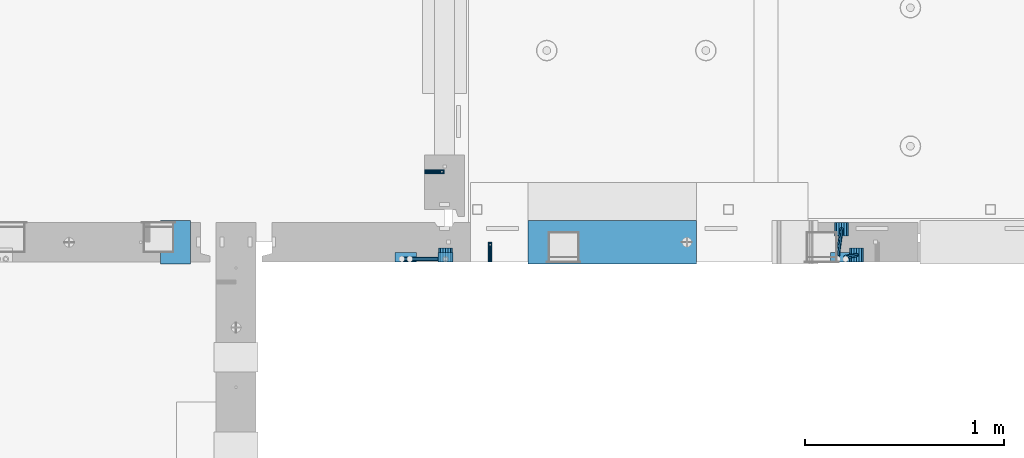
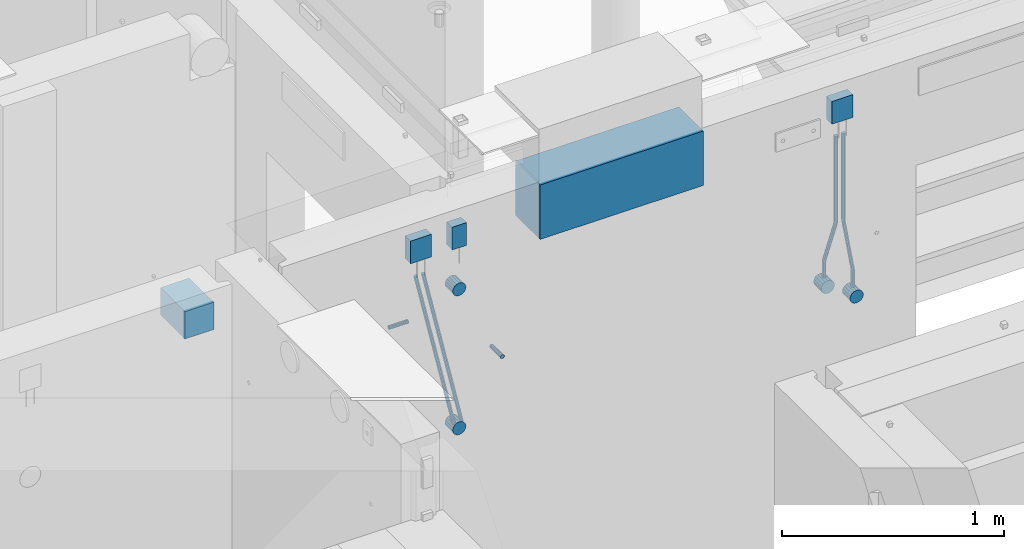
# One storey, part 92 of 264: 13 beams, 2 members, 6 elements without a shape of their own.
"""IFC2X3 building model written with IfcOpenShell, lengths in millimetres."""

from ifc_helpers import new_model, si_unit, frame, origin_with_axes, place, context, subcontext, project, spatial, faceted_brep, material, type_object, element, aggregate, save


model = new_model("IFC2X3")

# Units and contexts
model_context = context("Model", 3, precision=1e-05, world=origin_with_axes())
body_context = subcontext(model_context, "Body", "Model", "MODEL_VIEW")
ifc_project = project(units=[si_unit("LENGTHUNIT", "METRE", prefix="MILLI"), si_unit("AREAUNIT", "SQUARE_METRE"), si_unit("VOLUMEUNIT", "CUBIC_METRE"), si_unit("MASSUNIT", "GRAM", prefix="KILO"), si_unit("TIMEUNIT", "SECOND"), si_unit("PLANEANGLEUNIT", "RADIAN"), si_unit("SOLIDANGLEUNIT", "STERADIAN"), si_unit("THERMODYNAMICTEMPERATUREUNIT", "DEGREE_CELSIUS"), si_unit("LUMINOUSINTENSITYUNIT", "LUMEN")], contexts=[model_context])

# Site, building, storey
site_placement = place(None, origin_with_axes())
site = spatial("IfcSite", under=ifc_project, at=site_placement, CompositionType="ELEMENT")
building_placement = place(site_placement, origin_with_axes())
building = spatial("IfcBuilding", under=site, at=building_placement, CompositionType="ELEMENT")
storey_placement = place(building_placement, origin_with_axes())
storey = spatial("IfcBuildingStorey", under=building, at=storey_placement, Name="K", CompositionType="ELEMENT", Elevation=0.0)

# Assemblies, beam
assembly_1_placement = place(storey_placement, origin_with_axes())
assembly_1 = element("IfcElementAssembly", 1, at=assembly_1_placement, inside=storey, AssemblyPlace="NOTDEFINED", PredefinedType="REINFORCEMENT_UNIT")
assembly_2_placement = place(assembly_1_placement, origin_with_axes())
assembly_2 = element("IfcElementAssembly", 2, at=assembly_2_placement, Name="Steel Assembly", AssemblyPlace="NOTDEFINED", PredefinedType="RIGID_FRAME")
ifc_material_1 = material(Name="STEEL/Steel_Undefined")
beam_type_1 = type_object("IfcBeamType", PredefinedType="NOTDEFINED")
beam_1_placement = place(assembly_2_placement, frame((17939.9947677822, 15080.0, 80575.0), z_axis=(-1.0, 3.00000001838171e-08, 0.0), x_axis=(0.0, 1.0, 0.0)))
beam_1 = element("IfcBeam", 3, at=beam_1_placement, type_object=beam_type_1, material=ifc_material_1, Name="M16", context=body_context, shape_type="Brep", body=[
    faceted_brep([(0.0, -8.49999999999272, -1.45519152283669e-11), (0.0, -7.36121593215648, 4.24999999998545), (100.000000000262, -7.36121593215648, 4.24999999998545), (100.000000000262, -8.49999999999272, -1.45519152283669e-11), (0.0, -4.24999999998545, 7.36121593216376), (100.000000000262, -4.24999999998545, 7.36121593216376), (0.0, 1.45519152283669e-11, 8.49999999998545), (100.000000000262, 1.45519152283669e-11, 8.49999999998545), (0.0, 4.25000000001455, 7.36121593216376), (100.000000000262, 4.25000000001455, 7.36121593216376), (0.0, 7.36121593217104, 4.24999999998545), (100.000000000262, 7.36121593217104, 4.24999999998545), (0.0, 8.50000000000728, 0.0), (100.000000000262, 8.50000000000728, 0.0), (0.0, 7.36121593217104, -4.25000000001455), (100.000000000262, 7.36121593217104, -4.25000000001455), (0.0, 4.25000000000728, -7.36121593219286), (100.000000000262, 4.25000000000728, -7.36121593219286), (0.0, 7.27595761418343e-12, -8.5), (100.000000000262, 7.27595761418343e-12, -8.5), (0.0, -4.24999999999272, -7.36121593217831), (100.000000000262, -4.24999999999272, -7.36121593217831), (0.0, -7.36121593215648, -4.25), (100.000000000262, -7.36121593215648, -4.25), (0.0, -10.4999999999927, -1.45519152283669e-11), (0.0, -9.09326673972828, -5.25000000001455), (100.000000000262, -9.09326673972828, -5.25000000001455), (100.000000000262, -10.4999999999927, -1.45519152283669e-11), (0.0, -5.24999999998545, -9.09326673974283), (100.000000000262, -5.24999999998545, -9.09326673974283), (0.0, 7.27595761418343e-12, -10.5), (100.000000000262, 7.27595761418343e-12, -10.5), (0.0, 5.25000000001455, -9.09326673975738), (100.000000000262, 5.25000000001455, -9.09326673975738), (0.0, 9.09326673975011, -5.25000000001455), (100.000000000262, 9.09326673975011, -5.25000000001455), (0.0, 10.5000000000073, -1.45519152283669e-11), (100.000000000262, 10.5000000000073, -1.45519152283669e-11), (0.0, 9.09326673975011, 5.25), (100.000000000262, 9.09326673975011, 5.25), (0.0, 5.25000000000728, 9.09326673972828), (100.000000000262, 5.25000000000728, 9.09326673972828), (0.0, 1.45519152283669e-11, 10.4999999999854), (100.000000000262, 1.45519152283669e-11, 10.4999999999854), (0.0, -5.24999999999272, 9.09326673972828), (100.000000000262, -5.24999999999272, 9.09326673972828), (0.0, -9.09326673972828, 5.24999999998545), (100.000000000262, -9.09326673972828, 5.24999999998545)], [[[0, 1, 2, 3]], [[1, 4, 5, 2]], [[4, 6, 7, 5]], [[6, 8, 9, 7]], [[8, 10, 11, 9]], [[10, 12, 13, 11]], [[12, 14, 15, 13]], [[14, 16, 17, 15]], [[16, 18, 19, 17]], [[18, 20, 21, 19]], [[20, 22, 23, 21]], [[22, 0, 3, 23]], [[24, 25, 26, 27]], [[25, 28, 29, 26]], [[28, 30, 31, 29]], [[30, 32, 33, 31]], [[32, 34, 35, 33]], [[34, 36, 37, 35]], [[36, 38, 39, 37]], [[38, 40, 41, 39]], [[40, 42, 43, 41]], [[42, 44, 45, 43]], [[44, 46, 47, 45]], [[46, 24, 27, 47]], [[29, 31, 33, 35, 37, 39, 41, 43, 45, 47, 27, 26], [5, 7, 9, 11, 13, 15, 17, 19, 21, 23, 3, 2]], [[46, 44, 42, 40, 38, 36, 34, 32, 30, 28, 25, 24], [22, 20, 18, 16, 14, 12, 10, 8, 6, 4, 1, 0]]]),
])
aggregate(assembly_2, [beam_1])

assembly_3_placement = place(storey_placement, origin_with_axes())
assembly_3 = element("IfcElementAssembly", 4, at=assembly_3_placement, inside=storey, AssemblyPlace="NOTDEFINED", PredefinedType="REINFORCEMENT_UNIT")
assembly_4_placement = place(assembly_3_placement, origin_with_axes())
assembly_4 = element("IfcElementAssembly", 5, at=assembly_4_placement, Name="Steel Assembly", AssemblyPlace="NOTDEFINED", PredefinedType="RIGID_FRAME")
aggregate(assembly_3, [assembly_4])
beam_2_placement = place(assembly_4_placement, frame((17610.0, 15535.0002277642, 80575.0), z_axis=(0.0, -1.0, 0.0), x_axis=(1.0, 0.0, 0.0)))
beam_2 = element("IfcBeam", 6, at=beam_2_placement, type_object=beam_type_1, material=ifc_material_1, Name="M16", context=body_context, shape_type="Brep", body=[
    faceted_brep([(0.0, -8.49999999999272, -1.45519152283669e-11), (0.0, -7.36121593215648, 4.24999999998545), (100.000000000262, -7.36121593215648, 4.24999999998545), (100.000000000262, -8.49999999999272, -1.45519152283669e-11), (0.0, -4.24999999998545, 7.36121593216376), (100.000000000262, -4.24999999998545, 7.36121593216376), (0.0, 1.45519152283669e-11, 8.49999999998545), (100.000000000262, 1.45519152283669e-11, 8.49999999998545), (0.0, 4.25000000001455, 7.36121593216376), (100.000000000262, 4.25000000001455, 7.36121593216376), (0.0, 7.36121593217104, 4.24999999998545), (100.000000000262, 7.36121593217104, 4.24999999998545), (0.0, 8.50000000000728, 0.0), (100.000000000262, 8.50000000000728, 0.0), (0.0, 7.36121593217104, -4.25000000001455), (100.000000000262, 7.36121593217104, -4.25000000001455), (0.0, 4.25000000000728, -7.36121593219286), (100.000000000262, 4.25000000000728, -7.36121593219286), (0.0, 7.27595761418343e-12, -8.5), (100.000000000262, 7.27595761418343e-12, -8.5), (0.0, -4.24999999999272, -7.36121593217831), (100.000000000262, -4.24999999999272, -7.36121593217831), (0.0, -7.36121593215648, -4.25), (100.000000000262, -7.36121593215648, -4.25), (0.0, -10.4999999999927, -1.45519152283669e-11), (0.0, -9.09326673972828, -5.25000000001455), (100.000000000262, -9.09326673972828, -5.25000000001455), (100.000000000262, -10.4999999999927, -1.45519152283669e-11), (0.0, -5.24999999998545, -9.09326673974283), (100.000000000262, -5.24999999998545, -9.09326673974283), (0.0, 7.27595761418343e-12, -10.5), (100.000000000262, 7.27595761418343e-12, -10.5), (0.0, 5.25000000001455, -9.09326673975738), (100.000000000262, 5.25000000001455, -9.09326673975738), (0.0, 9.09326673975011, -5.25000000001455), (100.000000000262, 9.09326673975011, -5.25000000001455), (0.0, 10.5000000000073, -1.45519152283669e-11), (100.000000000262, 10.5000000000073, -1.45519152283669e-11), (0.0, 9.09326673975011, 5.25), (100.000000000262, 9.09326673975011, 5.25), (0.0, 5.25000000000728, 9.09326673972828), (100.000000000262, 5.25000000000728, 9.09326673972828), (0.0, 1.45519152283669e-11, 10.4999999999854), (100.000000000262, 1.45519152283669e-11, 10.4999999999854), (0.0, -5.24999999999272, 9.09326673972828), (100.000000000262, -5.24999999999272, 9.09326673972828), (0.0, -9.09326673972828, 5.24999999998545), (100.000000000262, -9.09326673972828, 5.24999999998545)], [[[0, 1, 2, 3]], [[1, 4, 5, 2]], [[4, 6, 7, 5]], [[6, 8, 9, 7]], [[8, 10, 11, 9]], [[10, 12, 13, 11]], [[12, 14, 15, 13]], [[14, 16, 17, 15]], [[16, 18, 19, 17]], [[18, 20, 21, 19]], [[20, 22, 23, 21]], [[22, 0, 3, 23]], [[24, 25, 26, 27]], [[25, 28, 29, 26]], [[28, 30, 31, 29]], [[30, 32, 33, 31]], [[32, 34, 35, 33]], [[34, 36, 37, 35]], [[36, 38, 39, 37]], [[38, 40, 41, 39]], [[40, 42, 43, 41]], [[42, 44, 45, 43]], [[44, 46, 47, 45]], [[46, 24, 27, 47]], [[29, 31, 33, 35, 37, 39, 41, 43, 45, 47, 27, 26], [5, 7, 9, 11, 13, 15, 17, 19, 21, 23, 3, 2]], [[46, 44, 42, 40, 38, 36, 34, 32, 30, 28, 25, 24], [22, 20, 18, 16, 14, 12, 10, 8, 6, 4, 1, 0]]]),
])
aggregate(assembly_4, [beam_2])

# Beam
ifc_material_2 = material()
beam_type_2 = type_object("IfcBeamType", Name="D20", PredefinedType="NOTDEFINED")
beam_3_placement = place(assembly_1_placement, frame((19710.0015915473, 15245.0, 80295.0), z_axis=(0.0, 1.0, 0.0), x_axis=(0.0, 0.0, 1.0)))
beam_3 = element("IfcBeam", 7, at=beam_3_placement, type_object=beam_type_2, material=ifc_material_2, Name="JM20", ObjectType="D20", context=body_context, shape_type="Brep", body=[
    faceted_brep([(0.0, -10.0, 0.0), (-4.19531716033816e-08, -7.07106781186667, -7.07106781187031), (78.8056231630762, -7.07106781227048, -7.07106781186485), (78.8056231629744, -10.0000000004184, -5.45696821063757e-11), (0.0, 0.0, -10.0), (78.8056231631053, -4.0381564758718e-10, -10.0), (4.196772351861e-08, 7.07106781186303, -7.07106781186667), (78.805623163149, 7.07106781145922, -7.07106781186485), (0.0, 10.0, 0.0), (78.8056231631635, 9.99999999959618, 0.0), (4.196772351861e-08, 7.07106781185939, 7.07106781185939), (78.805623163149, 7.07106781145922, 7.07106781186485), (0.0, 0.0, 10.0), (78.8056231631053, -4.0381564758718e-10, 10.0), (-4.19531716033816e-08, -7.07106781187031, 7.07106781185939), (78.8056231630762, -7.07106781227048, 7.07106781186485), (91.89239255547, -0.204646646245237, 8.56747361553062), (91.47739321478, 6.87291079041825, 5.68396879664579), (90.0385385497648, 9.82434332009507, -1.22959663939037), (88.4186901089124, 6.92074179533302, -8.12334982451102), (87.5667331398727, -0.137003390402242, -10.9590236385156), (87.9817324805626, -7.21456082705845, -8.07551881962718), (89.4205871455779, -10.1659933567425, -1.16195338358375), (91.0404355864594, -7.26239183197322, 5.73179980152236), (102.684103387292, -7.82711976362043, 1.77870465650449), (104.346853655268, -0.808698752247437, 4.3391092762231), (99.5226720854553, -10.6559531900675, -4.59167188944957), (96.7144833312923, -7.63810677580113, -11.0403401783733), (95.9045360098826, -0.541394021423912, -13.7897577859439), (97.5672862778447, 6.47702698995272, -11.2293531662181), (100.728717579055, 9.30586041629795, -4.85897662027128), (103.536906333829, 6.2880140021407, 1.589691668667), (376.463093666927, -26.2880159097986, -141.589691668629), (379.2712824216, -29.305862324014, -135.141023379647), (375.653146345459, -19.1913031554031, -144.339109276189), (377.315896613363, -12.1728821440483, -141.778704656472), (380.47732791453, -9.34404871774314, -135.408328110543), (383.285516669246, -12.3618951319222, -128.959659821587), (384.095463990714, -19.4586078863176, -126.210242214027), (382.43271372281, -26.4770288976688, -128.770646833744), (392.433266860797, -19.8629985172993, -129.040976361435), (392.018267520049, -12.7854410806176, -131.92448118032), (390.579412855048, -9.8340085509335, -138.838046616376), (388.959564414137, -12.7376100757028, -145.731799801475), (388.107607445068, -19.7953552614381, -148.567473615452), (388.522606785802, -26.8729126981307, -145.683968796564), (389.961461450905, -29.8243452278111, -138.770403360531), (391.581309891801, -26.9207437030454, -131.876650175422), (401.194376837579, -27.071069719168, -132.928932188157), (401.19437683768, -20.0000019072831, -129.999999999964), (401.194376836909, -30.0000019073486, -140.000000000011), (401.194376837258, -27.0710697191571, -147.071067811921), (401.194376837258, -20.0000019072577, -150.000000000027), (401.194376837389, -12.9289340953765, -147.071067811843), (401.194376837564, -10.0000019072322, -139.999999999947), (401.194376837666, -12.9289340953801, -132.928932188071), (872.5, -27.0710697192044, -147.071067811874), (872.5, -30.0000019073486, -140.000000000011), (872.5, -20.0000019073377, -150.0), (872.5, -12.9289340954747, -147.071067811858), (872.5, -10.0000019073486, -139.999999999989), (872.5, -12.9289340954929, -132.928932188126), (872.5, -20.0000019073595, -130.0), (872.5, -27.0710697192226, -132.928932188142)], [[[0, 1, 2, 3]], [[1, 4, 5, 2]], [[4, 6, 7, 5]], [[6, 8, 9, 7]], [[8, 10, 11, 9]], [[10, 12, 13, 11]], [[12, 14, 15, 13]], [[14, 0, 3, 15]], [[14, 12, 10, 8, 6, 4, 1, 0]], [[11, 13, 16, 17]], [[9, 11, 17, 18]], [[7, 9, 18, 19]], [[5, 7, 19, 20]], [[2, 5, 20, 21]], [[3, 2, 21, 22]], [[15, 3, 22, 23]], [[13, 15, 23, 16]], [[23, 24, 25, 16]], [[22, 26, 24, 23]], [[21, 27, 26, 22]], [[20, 28, 27, 21]], [[19, 29, 28, 20]], [[18, 30, 29, 19]], [[17, 31, 30, 18]], [[16, 25, 31, 17]], [[26, 27, 32, 33]], [[27, 28, 34, 32]], [[28, 29, 35, 34]], [[29, 30, 36, 35]], [[30, 31, 37, 36]], [[31, 25, 38, 37]], [[25, 24, 39, 38]], [[24, 26, 33, 39]], [[37, 38, 40, 41]], [[36, 37, 41, 42]], [[35, 36, 42, 43]], [[34, 35, 43, 44]], [[32, 34, 44, 45]], [[33, 32, 45, 46]], [[39, 33, 46, 47]], [[38, 39, 47, 40]], [[47, 48, 49, 40]], [[46, 50, 48, 47]], [[45, 51, 50, 46]], [[44, 52, 51, 45]], [[43, 53, 52, 44]], [[42, 54, 53, 43]], [[41, 55, 54, 42]], [[40, 49, 55, 41]], [[50, 51, 56, 57]], [[51, 52, 58, 56]], [[52, 53, 59, 58]], [[53, 54, 60, 59]], [[54, 55, 61, 60]], [[55, 49, 62, 61]], [[49, 48, 63, 62]], [[48, 50, 57, 63]], [[58, 59, 60, 61, 62, 63, 57, 56]]]),
])

beam_4_placement = place(assembly_1_placement, frame((19785.0015915473, 15115.0, 80295.0), z_axis=(0.0, 1.0, 0.0), x_axis=(0.0, 0.0, 1.0)))
beam_4 = element("IfcBeam", 8, at=beam_4_placement, type_object=beam_type_2, material=ifc_material_2, Name="JM20", ObjectType="D20", context=body_context, shape_type="Brep", body=[
    faceted_brep([(0.0, -10.0, 0.0), (-4.19531716033816e-08, -7.07106781186667, -7.07106781187031), (85.381276020853, -7.07106781186667, -7.07106781186485), (85.381276020853, -10.0000000000073, -9.09494701772928e-11), (0.0, 0.0, -10.0), (85.381276020853, 0.0, -10.0), (4.196772351861e-08, 7.07106781186303, -7.07106781186667), (85.381276020853, 7.07106781186667, -7.07106781186485), (0.0, 10.0, 0.0), (85.381276020853, 10.0, 0.0), (4.196772351861e-08, 7.07106781185939, 7.07106781185939), (85.381276020853, 7.07106781186667, 7.07106781186485), (0.0, 0.0, 10.0), (85.381276020853, 0.0, 10.0), (-4.19531716033816e-08, -7.07106781187031, 7.07106781185939), (85.381276020853, -7.07106781186667, 7.07106781186485), (93.0344277782715, -7.76662046025376, -7.19753192979806), (92.7382571138005, -10.6686353342229, -0.121570060768136), (94.2128745706141, -0.802655161623989, -10.1459373021571), (95.5832793423033, 6.14386413761531, -7.23965029812825), (96.3428775639914, 9.00376064326338, -0.181134428517908), (96.0467068993603, 6.10174576930513, 6.89482744047746), (94.8682601069886, -0.86221952932101, 9.84323281283832), (93.4978553353139, -7.80873882856758, 6.93694580880947), (383.953293100509, -61.1017457692979, -16.8948274404884), (383.657122435907, -64.0037606432743, -9.8188655715112), (385.131739892851, -54.1377804706644, -19.8432328128474), (386.502144664511, -47.1912611714215, -16.9369458088258), (387.2617428862, -44.3313646657771, -9.87842993923186), (386.965572221598, -47.2333795397572, -2.80246807024741), (385.78712542927, -54.1973448383906, 0.145937302111633), (384.416720657609, -61.1438641376335, -2.76034970190995), (394.618723979031, -62.0710678119103, -17.0710678119503), (394.618723979147, -65.0, -10.0), (394.618723979031, -55.0000000000218, -20.0000000000528), (394.618723979045, -47.9289321881624, -17.0710678118739), (394.618723979016, -45.0000000000546, -9.99999999997999), (394.618723979016, -47.9289321882061, -2.92893218810968), (394.618723979002, -55.0000000000873, -1.2732925824821e-11), (394.618723978987, -62.071067811954, -2.92893218818972), (872.5, -62.0710678118667, -17.0710678118649), (872.5, -65.0, -10.0), (872.5, -55.0, -20.0), (872.5, -47.9289321881333, -17.0710678118649), (872.5, -45.0, -10.0), (872.5, -47.9289321881333, -2.92893218813515), (872.5, -55.0, 0.0), (872.5, -62.0710678118667, -2.92893218813515)], [[[0, 1, 2, 3]], [[1, 4, 5, 2]], [[4, 6, 7, 5]], [[6, 8, 9, 7]], [[8, 10, 11, 9]], [[10, 12, 13, 11]], [[12, 14, 15, 13]], [[14, 0, 3, 15]], [[14, 12, 10, 8, 6, 4, 1, 0]], [[3, 2, 16, 17]], [[2, 5, 18, 16]], [[5, 7, 19, 18]], [[7, 9, 20, 19]], [[9, 11, 21, 20]], [[11, 13, 22, 21]], [[13, 15, 23, 22]], [[15, 3, 17, 23]], [[17, 16, 24, 25]], [[16, 18, 26, 24]], [[18, 19, 27, 26]], [[19, 20, 28, 27]], [[20, 21, 29, 28]], [[21, 22, 30, 29]], [[22, 23, 31, 30]], [[23, 17, 25, 31]], [[25, 24, 32, 33]], [[24, 26, 34, 32]], [[26, 27, 35, 34]], [[27, 28, 36, 35]], [[28, 29, 37, 36]], [[29, 30, 38, 37]], [[30, 31, 39, 38]], [[31, 25, 33, 39]], [[33, 32, 40, 41]], [[32, 34, 42, 40]], [[34, 35, 43, 42]], [[35, 36, 44, 43]], [[36, 37, 45, 44]], [[37, 38, 46, 45]], [[38, 39, 47, 46]], [[39, 33, 41, 47]], [[42, 43, 44, 45, 46, 47, 41, 40]]]),
])

beam_type_3 = type_object("IfcBeamType", Name="D70", PredefinedType="NOTDEFINED")
beam_5_placement = place(assembly_1_placement, frame((19710.0015915445, 15210.0, 80260.0), z_axis=(0.0, 0.0, 1.0), x_axis=(0.0, 1.0, 0.0)))
beam_5 = element("IfcBeam", 9, at=beam_5_placement, type_object=beam_type_3, material=ifc_material_2, ObjectType="D70", context=body_context, shape_type="Brep", body=[
    faceted_brep([(0.0, -35.0, 0.0), (0.0, -32.3357836378964, -13.3939201327739), (70.0, -32.3357836378964, -13.3939201327739), (70.0, -35.0, 0.0), (0.0, -24.7487373415279, -24.7487373415352), (70.0, -24.7487373415279, -24.7487373415352), (0.0, -13.3939201327776, -32.3357836379), (70.0, -13.3939201327776, -32.3357836379), (0.0, 0.0, -35.0), (70.0, 0.0, -35.0), (0.0, 13.3939201327776, -32.3357836379), (70.0, 13.3939201327776, -32.3357836379), (0.0, 24.7487373415279, -24.7487373415352), (70.0, 24.7487373415279, -24.7487373415352), (0.0, 32.3357836378964, -13.3939201327739), (70.0, 32.3357836378964, -13.3939201327739), (0.0, 35.0, 0.0), (70.0, 35.0, 0.0), (0.0, 32.3357836378964, 13.3939201327739), (70.0, 32.3357836378964, 13.3939201327739), (0.0, 24.7487373415279, 24.7487373415352), (70.0, 24.7487373415279, 24.7487373415352), (0.0, 13.3939201327776, 32.3357836379), (70.0, 13.3939201327776, 32.3357836379), (0.0, 0.0, 35.0), (70.0, 0.0, 35.0), (0.0, -13.3939201327776, 32.3357836379), (70.0, -13.3939201327776, 32.3357836379), (0.0, -24.7487373415279, 24.7487373415352), (70.0, -24.7487373415279, 24.7487373415352), (0.0, -32.3357836378964, 13.3939201327739), (70.0, -32.3357836378964, 13.3939201327739)], [[[0, 1, 2, 3]], [[1, 4, 5, 2]], [[4, 6, 7, 5]], [[6, 8, 9, 7]], [[8, 10, 11, 9]], [[10, 12, 13, 11]], [[12, 14, 15, 13]], [[14, 16, 17, 15]], [[16, 18, 19, 17]], [[18, 20, 21, 19]], [[20, 22, 23, 21]], [[22, 24, 25, 23]], [[24, 26, 27, 25]], [[26, 28, 29, 27]], [[28, 30, 31, 29]], [[30, 0, 3, 31]], [[5, 7, 9, 11, 13, 15, 17, 19, 21, 23, 25, 27, 29, 31, 3, 2]], [[30, 28, 26, 24, 22, 20, 18, 16, 14, 12, 10, 8, 6, 4, 1, 0]]]),
])

beam_6_placement = place(assembly_1_placement, frame((19785.0015915445, 15080.0, 80260.0), z_axis=(0.0, 0.0, 1.0), x_axis=(0.0, 1.0, 0.0)))
beam_6 = element("IfcBeam", 10, at=beam_6_placement, type_object=beam_type_3, material=ifc_material_2, ObjectType="D70", context=body_context, shape_type="Brep", body=[
    faceted_brep([(0.0, -35.0, 0.0), (0.0, -32.3357836378964, -13.3939201327739), (70.0, -32.3357836378964, -13.3939201327739), (70.0, -35.0, 0.0), (0.0, -24.7487373415279, -24.7487373415352), (70.0, -24.7487373415279, -24.7487373415352), (0.0, -13.3939201327776, -32.3357836379), (70.0, -13.3939201327776, -32.3357836379), (0.0, 0.0, -35.0), (70.0, 0.0, -35.0), (0.0, 13.3939201327776, -32.3357836379), (70.0, 13.3939201327776, -32.3357836379), (0.0, 24.7487373415279, -24.7487373415352), (70.0, 24.7487373415279, -24.7487373415352), (0.0, 32.3357836378964, -13.3939201327739), (70.0, 32.3357836378964, -13.3939201327739), (0.0, 35.0, 0.0), (70.0, 35.0, 0.0), (0.0, 32.3357836378964, 13.3939201327739), (70.0, 32.3357836378964, 13.3939201327739), (0.0, 24.7487373415279, 24.7487373415352), (70.0, 24.7487373415279, 24.7487373415352), (0.0, 13.3939201327776, 32.3357836379), (70.0, 13.3939201327776, 32.3357836379), (0.0, 0.0, 35.0), (70.0, 0.0, 35.0), (0.0, -13.3939201327776, 32.3357836379), (70.0, -13.3939201327776, 32.3357836379), (0.0, -24.7487373415279, 24.7487373415352), (70.0, -24.7487373415279, 24.7487373415352), (0.0, -32.3357836378964, 13.3939201327739), (70.0, -32.3357836378964, 13.3939201327739)], [[[0, 1, 2, 3]], [[1, 4, 5, 2]], [[4, 6, 7, 5]], [[6, 8, 9, 7]], [[8, 10, 11, 9]], [[10, 12, 13, 11]], [[12, 14, 15, 13]], [[14, 16, 17, 15]], [[16, 18, 19, 17]], [[18, 20, 21, 19]], [[20, 22, 23, 21]], [[22, 24, 25, 23]], [[24, 26, 27, 25]], [[26, 28, 29, 27]], [[28, 30, 31, 29]], [[30, 0, 3, 31]], [[5, 7, 9, 11, 13, 15, 17, 19, 21, 23, 25, 27, 29, 31, 3, 2]], [[30, 28, 26, 24, 22, 20, 18, 16, 14, 12, 10, 8, 6, 4, 1, 0]]]),
])

beam_7_placement = place(assembly_1_placement, frame((17715.0015915445, 15080.0, 81025.0), z_axis=(0.0, 0.0, 1.0), x_axis=(0.0, 1.0, 0.0)))
beam_7 = element("IfcBeam", 11, at=beam_7_placement, type_object=beam_type_3, material=ifc_material_2, ObjectType="D70", context=body_context, shape_type="Brep", body=[
    faceted_brep([(0.0, -35.0, 0.0), (0.0, -32.3357836378964, -13.3939201327739), (70.0, -32.3357836378964, -13.3939201327739), (70.0, -35.0, 0.0), (0.0, -24.7487373415279, -24.7487373415352), (70.0, -24.7487373415279, -24.7487373415352), (0.0, -13.3939201327776, -32.3357836379), (70.0, -13.3939201327776, -32.3357836379), (0.0, 0.0, -35.0), (70.0, 0.0, -35.0), (0.0, 13.3939201327776, -32.3357836379), (70.0, 13.3939201327776, -32.3357836379), (0.0, 24.7487373415279, -24.7487373415352), (70.0, 24.7487373415279, -24.7487373415352), (0.0, 32.3357836378964, -13.3939201327739), (70.0, 32.3357836378964, -13.3939201327739), (0.0, 35.0, 0.0), (70.0, 35.0, 0.0), (0.0, 32.3357836378964, 13.3939201327739), (70.0, 32.3357836378964, 13.3939201327739), (0.0, 24.7487373415279, 24.7487373415352), (70.0, 24.7487373415279, 24.7487373415352), (0.0, 13.3939201327776, 32.3357836379), (70.0, 13.3939201327776, 32.3357836379), (0.0, 0.0, 35.0), (70.0, 0.0, 35.0), (0.0, -13.3939201327776, 32.3357836379), (70.0, -13.3939201327776, 32.3357836379), (0.0, -24.7487373415279, 24.7487373415352), (70.0, -24.7487373415279, 24.7487373415352), (0.0, -32.3357836378964, 13.3939201327739), (70.0, -32.3357836378964, 13.3939201327739)], [[[0, 1, 2, 3]], [[1, 4, 5, 2]], [[4, 6, 7, 5]], [[6, 8, 9, 7]], [[8, 10, 11, 9]], [[10, 12, 13, 11]], [[12, 14, 15, 13]], [[14, 16, 17, 15]], [[16, 18, 19, 17]], [[18, 20, 21, 19]], [[20, 22, 23, 21]], [[22, 24, 25, 23]], [[24, 26, 27, 25]], [[26, 28, 29, 27]], [[28, 30, 31, 29]], [[30, 0, 3, 31]], [[5, 7, 9, 11, 13, 15, 17, 19, 21, 23, 25, 27, 29, 31, 3, 2]], [[30, 28, 26, 24, 22, 20, 18, 16, 14, 12, 10, 8, 6, 4, 1, 0]]]),
])

beam_8_placement = place(assembly_1_placement, frame((17715.0015915445, 15080.0, 80260.0), z_axis=(0.0, 0.0, 1.0), x_axis=(0.0, 1.0, 0.0)))
beam_8 = element("IfcBeam", 12, at=beam_8_placement, type_object=beam_type_3, material=ifc_material_2, ObjectType="D70", context=body_context, shape_type="Brep", body=[
    faceted_brep([(0.0, -35.0, 0.0), (0.0, -32.3357836378964, -13.3939201327739), (70.0, -32.3357836378964, -13.3939201327739), (70.0, -35.0, 0.0), (0.0, -24.7487373415279, -24.7487373415352), (70.0, -24.7487373415279, -24.7487373415352), (0.0, -13.3939201327776, -32.3357836379), (70.0, -13.3939201327776, -32.3357836379), (0.0, 0.0, -35.0), (70.0, 0.0, -35.0), (0.0, 13.3939201327776, -32.3357836379), (70.0, 13.3939201327776, -32.3357836379), (0.0, 24.7487373415279, -24.7487373415352), (70.0, 24.7487373415279, -24.7487373415352), (0.0, 32.3357836378964, -13.3939201327739), (70.0, 32.3357836378964, -13.3939201327739), (0.0, 35.0, 0.0), (70.0, 35.0, 0.0), (0.0, 32.3357836378964, 13.3939201327739), (70.0, 32.3357836378964, 13.3939201327739), (0.0, 24.7487373415279, 24.7487373415352), (70.0, 24.7487373415279, 24.7487373415352), (0.0, 13.3939201327776, 32.3357836379), (70.0, 13.3939201327776, 32.3357836379), (0.0, 0.0, 35.0), (70.0, 0.0, 35.0), (0.0, -13.3939201327776, 32.3357836379), (70.0, -13.3939201327776, 32.3357836379), (0.0, -24.7487373415279, 24.7487373415352), (70.0, -24.7487373415279, 24.7487373415352), (0.0, -32.3357836378964, 13.3939201327739), (70.0, -32.3357836378964, 13.3939201327739)], [[[0, 1, 2, 3]], [[1, 4, 5, 2]], [[4, 6, 7, 5]], [[6, 8, 9, 7]], [[8, 10, 11, 9]], [[10, 12, 13, 11]], [[12, 14, 15, 13]], [[14, 16, 17, 15]], [[16, 18, 19, 17]], [[18, 20, 21, 19]], [[20, 22, 23, 21]], [[22, 24, 25, 23]], [[24, 26, 27, 25]], [[26, 28, 29, 27]], [[28, 30, 31, 29]], [[30, 0, 3, 31]], [[5, 7, 9, 11, 13, 15, 17, 19, 21, 23, 25, 27, 29, 31, 3, 2]], [[30, 28, 26, 24, 22, 20, 18, 16, 14, 12, 10, 8, 6, 4, 1, 0]]]),
])

beam_type_4 = type_object("IfcBeamType", Name="125X50", PredefinedType="NOTDEFINED")
beam_9_placement = place(assembly_1_placement, frame((19764.9998715127, 15104.0, 81317.5), z_axis=(0.0, 0.0, 1.0), x_axis=(-1.0, 3.00000001838171e-08, 0.0)))
beam_9 = element("IfcBeam", 13, at=beam_9_placement, type_object=beam_type_4, material=ifc_material_2, Name="WM2", ObjectType="125X50", context=body_context, shape_type="Brep", body=[
    faceted_brep([(0.0, 25.0, -62.5), (0.0, 25.0, 62.5), (110.0, 25.0, 62.5), (110.0, 25.0, -62.5), (0.0, -25.0, 62.5), (110.0, -25.0, 62.5), (0.0, -25.0, -62.5), (110.0, -25.0, -62.5)], [[[0, 1, 2, 3]], [[1, 4, 5, 2]], [[4, 6, 7, 5]], [[6, 0, 3, 7]], [[5, 7, 3, 2]], [[0, 6, 4, 1]]]),
])

beam_10_placement = place(assembly_1_placement, frame((17752.4998715127, 15104.0, 81317.5), z_axis=(0.0, 0.0, 1.0), x_axis=(-1.0, 3.00000001838171e-08, 0.0)))
beam_10 = element("IfcBeam", 14, at=beam_10_placement, type_object=beam_type_4, material=ifc_material_2, Name="WM1", ObjectType="125X50", context=body_context, shape_type="Brep", body=[
    faceted_brep([(0.0, 25.0, -62.5), (0.0, 25.0, 62.5), (75.0, 25.0, 62.5), (75.0, 25.0, -62.5), (0.0, -25.0, 62.5), (75.0, -25.0, 62.5), (0.0, -25.0, -62.5), (75.0, -25.0, -62.5)], [[[0, 1, 2, 3]], [[1, 4, 5, 2]], [[4, 6, 7, 5]], [[6, 0, 3, 7]], [[5, 7, 3, 2]], [[0, 6, 4, 1]]]),
])

beam_11_placement = place(assembly_1_placement, frame((17569.9998715127, 15104.0, 81317.5), z_axis=(0.0, 0.0, 1.0), x_axis=(-1.0, 3.00000001838171e-08, 0.0)))
beam_11 = element("IfcBeam", 15, at=beam_11_placement, type_object=beam_type_4, material=ifc_material_2, Name="WM2", ObjectType="125X50", context=body_context, shape_type="Brep", body=[
    faceted_brep([(0.0, 25.0, -62.5), (0.0, 25.0, 62.5), (110.0, 25.0, 62.5), (110.0, 25.0, -62.5), (0.0, -25.0, 62.5), (110.0, -25.0, 62.5), (0.0, -25.0, -62.5), (110.0, -25.0, -62.5)], [[[0, 1, 2, 3]], [[1, 4, 5, 2]], [[4, 6, 7, 5]], [[6, 0, 3, 7]], [[5, 7, 3, 2]], [[0, 6, 4, 1]]]),
])

# Member
member_type = type_object("IfcMemberType", Name="D20", PredefinedType="NOTDEFINED")
member_1_placement = place(assembly_1_placement, frame((17735.0015915473, 15095.0, 80285.0), z_axis=(0.0, -1.0, 0.0), x_axis=(-0.221023993110056, 0.0, 0.975268370485625)))
member_1 = element("IfcMember", 16, at=member_1_placement, type_object=member_type, material=ifc_material_2, Name="JM20", ObjectType="D20", context=body_context, shape_type="Brep", body=[
    faceted_brep([(0.0, -10.0, 0.0), (-4.19531716033816e-08, -7.07106781186667, -7.07106781187031), (904.879135575713, -7.07106781187031, -7.07106781186485), (904.879135575713, -10.0, 0.0), (0.0, 0.0, -10.0), (904.879135575713, 0.0, -10.0), (4.196772351861e-08, 7.07106781186303, -7.07106781186667), (904.879135575713, 7.07106781185576, -7.07106781186485), (0.0, 10.0, 0.0), (904.879135575713, 10.0, 0.0), (4.196772351861e-08, 7.07106781185939, 7.07106781185939), (904.879135575713, 7.07106781185576, 7.07106781186485), (0.0, 0.0, 10.0), (904.879135575713, 0.0, 10.0), (-4.19531716033816e-08, -7.07106781187031, 7.07106781185939), (904.879135575713, -7.07106781187031, 7.07106781186485)], [[[0, 1, 2, 3]], [[1, 4, 5, 2]], [[4, 6, 7, 5]], [[6, 8, 9, 7]], [[8, 10, 11, 9]], [[10, 12, 13, 11]], [[12, 14, 15, 13]], [[14, 0, 3, 15]], [[5, 7, 9, 11, 13, 15, 3, 2]], [[14, 12, 10, 8, 6, 4, 1, 0]]]),
])

member_2_placement = place(assembly_1_placement, frame((17695.0015915473, 15095.0, 80285.0), z_axis=(0.0, -1.0, 0.0), x_axis=(-0.221023993110056, 0.0, 0.975268370485625)))
member_2 = element("IfcMember", 17, at=member_2_placement, type_object=member_type, material=ifc_material_2, Name="JM20", ObjectType="D20", context=body_context, shape_type="Brep", body=[
    faceted_brep([(0.0, -10.0, 0.0), (-4.19531716033816e-08, -7.07106781186667, -7.07106781187031), (904.879135575713, -7.07106781187031, -7.07106781186485), (904.879135575713, -10.0, 0.0), (0.0, 0.0, -10.0), (904.879135575713, 0.0, -10.0), (4.196772351861e-08, 7.07106781186303, -7.07106781186667), (904.879135575713, 7.07106781185576, -7.07106781186485), (0.0, 10.0, 0.0), (904.879135575713, 10.0, 0.0), (4.196772351861e-08, 7.07106781185939, 7.07106781185939), (904.879135575713, 7.07106781185576, 7.07106781186485), (0.0, 0.0, 10.0), (904.879135575713, 0.0, 10.0), (-4.19531716033816e-08, -7.07106781187031, 7.07106781185939), (904.879135575713, -7.07106781187031, 7.07106781186485)], [[[0, 1, 2, 3]], [[1, 4, 5, 2]], [[4, 6, 7, 5]], [[6, 8, 9, 7]], [[8, 10, 11, 9]], [[10, 12, 13, 11]], [[12, 14, 15, 13]], [[14, 0, 3, 15]], [[5, 7, 9, 11, 13, 15, 3, 2]], [[14, 12, 10, 8, 6, 4, 1, 0]]]),
])

aggregate(assembly_1, [beam_3, beam_4, beam_9, beam_5, beam_6, beam_10, beam_7, member_1, member_2, beam_11, beam_8, assembly_2])

# Assembly, beam
assembly_5_placement = place(storey_placement, origin_with_axes())
assembly_5 = element("IfcElementAssembly", 18, at=assembly_5_placement, inside=storey, Name="Steel Assembly", AssemblyPlace="NOTDEFINED", PredefinedType="NOTDEFINED")
ifc_material_3 = material()
beam_type_5 = type_object("IfcBeamType", PredefinedType="NOTDEFINED")
beam_12_placement = place(assembly_5_placement, frame((18555.0000366569, 15069.9999222159, 81310.0), z_axis=(-1.0, 3.00000001838171e-08, 0.0), x_axis=(0.0, 1.0, 0.0)))
beam_12 = element("IfcBeam", 19, at=beam_12_placement, type_object=beam_type_5, material=ifc_material_3, context=body_context, shape_type="Brep", body=[
    faceted_brep([(0.0, 150.0, -425.0), (0.0, 150.0, 425.0), (220.000077784061, 150.0, 425.0), (220.000077784061, 150.0, -425.0), (0.0, -150.0, 425.0), (220.000077784061, -150.0, 425.0), (0.0, -150.0, -425.0), (220.000077784061, -150.0, -425.0)], [[[0, 1, 2, 3]], [[1, 4, 5, 2]], [[4, 6, 7, 5]], [[6, 0, 3, 7]], [[5, 7, 3, 2]], [[6, 4, 1, 0]]]),
])
aggregate(assembly_5, [beam_12])

assembly_6_placement = place(storey_placement, origin_with_axes())
assembly_6 = element("IfcElementAssembly", 20, at=assembly_6_placement, inside=storey, Name="Steel Assembly", AssemblyPlace="NOTDEFINED", PredefinedType="NOTDEFINED")
beam_type_6 = type_object("IfcBeamType", PredefinedType="NOTDEFINED")
beam_13_placement = place(assembly_6_placement, frame((16354.9999222159, 15070.0, 81335.0024432877), z_axis=(0.0, 0.0, 1.0), x_axis=(0.0, 1.0, 0.0)))
beam_13 = element("IfcBeam", 21, at=beam_13_placement, type_object=beam_type_6, material=ifc_material_3, context=body_context, shape_type="Brep", body=[
    faceted_brep([(0.0, 75.0, -75.0), (0.0, 75.0, 75.0), (219.999540746212, 75.0, 75.0), (219.999540746212, 75.0, -75.0), (0.0, -75.0, 75.0), (219.999540746212, -74.9999999999982, 75.0), (0.0, -75.0, -75.0), (219.999540746212, -74.9999999999982, -75.0)], [[[0, 1, 2, 3]], [[1, 4, 5, 2]], [[4, 6, 7, 5]], [[6, 0, 3, 7]], [[5, 7, 3, 2]], [[6, 4, 1, 0]]]),
])
aggregate(assembly_6, [beam_13])

save(model, "model.ifc")
